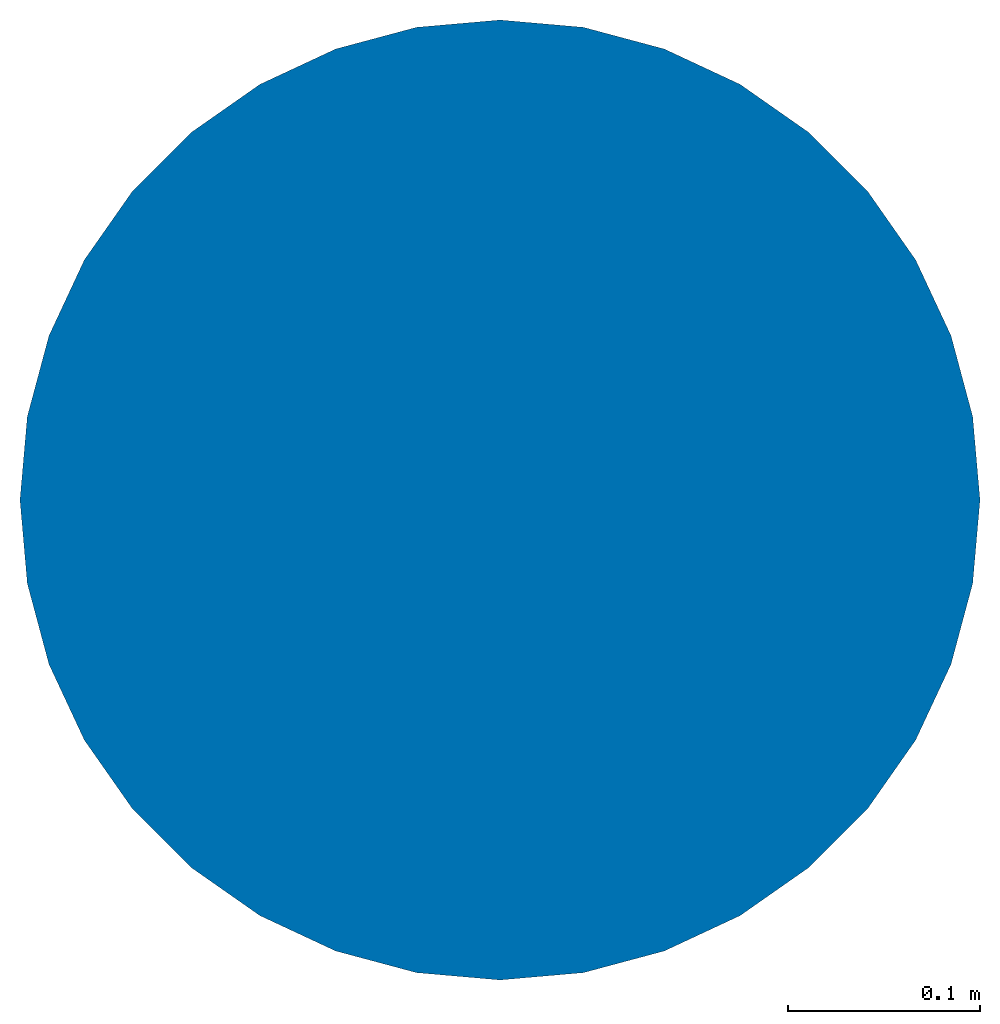
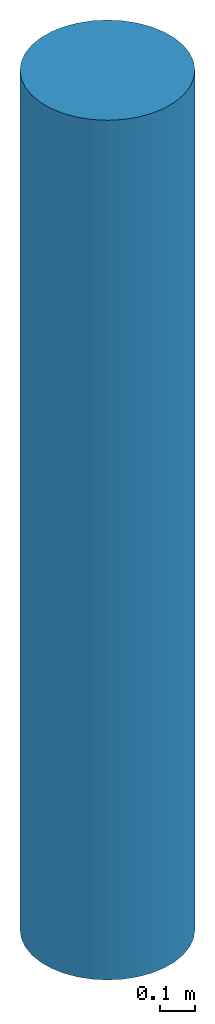
# One storey: 1 column.
"""IFC2X3 building model written with IfcOpenShell, lengths in millimetres."""

from ifc_helpers import new_model, entity, si_unit, converted_unit, derived_unit, money_unit, direction, frame, origin_with_axes, place, context, subcontext, project, spatial, faceted_brep, material, type_object, element, save


model = new_model("IFC2X3")

# Units and contexts
model_context = context("Model", 3, precision=1e-05, world=origin_with_axes(), true_north=direction((0.0, 1.0)))
body_context = subcontext(model_context, "Body", "Model", "MODEL_VIEW")
ifc_project = project(units=[si_unit("LENGTHUNIT", "METRE", prefix="MILLI"), si_unit("AREAUNIT", "SQUARE_METRE"), si_unit("VOLUMEUNIT", "CUBIC_METRE"), converted_unit("PLANEANGLEUNIT", "DEGREE", entity("IfcPlaneAngleMeasure", 0.0174532925199), si_unit("PLANEANGLEUNIT", "RADIAN"), dimensions=[0, 0, 0, 0, 0, 0, 0]), si_unit("SOLIDANGLEUNIT", "STERADIAN"), money_unit("USD"), converted_unit("TIMEUNIT", "Year", entity("IfcTimeMeasure", 31556926.0), si_unit("TIMEUNIT", "SECOND"), dimensions=[0, 0, 1, 0, 0, 0, 0]), si_unit("MASSUNIT", "GRAM", prefix="KILO"), si_unit("THERMODYNAMICTEMPERATUREUNIT", "DEGREE_CELSIUS"), si_unit("LUMINOUSINTENSITYUNIT", "LUMEN"), si_unit("ENERGYUNIT", "JOULE", prefix="MEGA"), derived_unit("THERMALCONDUCTANCEUNIT", [(si_unit("POWERUNIT", "WATT"), 1), (si_unit("LENGTHUNIT", "METRE"), -1), (si_unit("THERMODYNAMICTEMPERATUREUNIT", "KELVIN"), -1)]), derived_unit("SPECIFICHEATCAPACITYUNIT", [(si_unit("ENERGYUNIT", "JOULE"), 1), (si_unit("MASSUNIT", "GRAM", prefix="KILO"), -1), (si_unit("THERMODYNAMICTEMPERATUREUNIT", "KELVIN"), -1)]), derived_unit("MASSDENSITYUNIT", [(si_unit("MASSUNIT", "GRAM", prefix="KILO"), 1), (si_unit("VOLUMEUNIT", "CUBIC_METRE"), -1)])], contexts=[model_context])

# Site, building, storey
site_placement = place(None, origin_with_axes())
site = spatial("IfcSite", under=ifc_project, at=site_placement, CompositionType="ELEMENT")
building_placement = place(site_placement, origin_with_axes())
building = spatial("IfcBuilding", under=site, at=building_placement, CompositionType="ELEMENT")
storey_placement = place(building_placement, frame((0.0, 0.0, 500.0), z_axis=(0.0, 0.0, 1.0), x_axis=(1.0, 0.0, 0.0)))
storey = spatial("IfcBuildingStorey", under=building, at=storey_placement, Name="1FL", CompositionType="ELEMENT", Elevation=500.0)

# Column
ifc_material = material()
column_type = type_object("IfcColumnType", PredefinedType="NOTDEFINED")
column_placement = place(storey_placement, frame((852.21991327, 1196.77702465, 0.0), z_axis=(0.0, 0.0, 1.0), x_axis=(1.0, 0.0, 0.0)))
element("IfcColumn", 1, at=column_placement, inside=storey, type_object=column_type, material=ifc_material, Name="C1", context=body_context, shape_type="Brep", body=[
    faceted_brep([(-250.0, 0.0, 3000.0), (-250.0, 0.0, 0.0), (-246.201938253, -43.4120444167, 0.0), (-246.201938253, -43.4120444167, 3000.0), (-246.201938253, 43.4120444167, 3000.0), (-246.201938253, 43.4120444167, 0.0), (-234.923155196, 85.5050358314, 0.0), (-216.506350946, 125.0, 0.0), (-191.51111078, 160.696902422, 0.0), (-160.696902422, 191.51111078, 0.0), (-125.0, 216.506350946, 0.0), (-85.5050358314, 234.923155196, 0.0), (-43.4120444167, 246.201938253, 0.0), (0.0, 250.0, 0.0), (43.4120444167, 246.201938253, 0.0), (85.5050358314, 234.923155196, 0.0), (125.0, 216.506350946, 0.0), (160.696902422, 191.51111078, 0.0), (191.51111078, 160.696902422, 0.0), (216.506350946, 125.0, 0.0), (234.923155196, 85.5050358314, 0.0), (246.201938253, 43.4120444167, 0.0), (250.0, 0.0, 0.0), (246.201938253, -43.4120444167, 0.0), (234.923155196, -85.5050358314, 0.0), (216.506350946, -125.0, 0.0), (191.51111078, -160.696902422, 0.0), (160.696902422, -191.51111078, 0.0), (125.0, -216.506350946, 0.0), (85.5050358314, -234.923155196, 0.0), (43.4120444167, -246.201938253, 0.0), (0.0, -250.0, 0.0), (-43.4120444167, -246.201938253, 0.0), (-85.5050358314, -234.923155196, 0.0), (-125.0, -216.506350946, 0.0), (-160.696902422, -191.51111078, 0.0), (-191.51111078, -160.696902422, 0.0), (-216.506350946, -125.0, 0.0), (-234.923155196, -85.5050358314, 0.0), (-234.923155196, -85.5050358314, 3000.0), (-216.506350946, -125.0, 3000.0), (-191.51111078, -160.696902422, 3000.0), (-160.696902422, -191.51111078, 3000.0), (-125.0, -216.506350946, 3000.0), (-85.5050358314, -234.923155196, 3000.0), (-43.4120444167, -246.201938253, 3000.0), (0.0, -250.0, 3000.0), (43.4120444167, -246.201938253, 3000.0), (85.5050358314, -234.923155196, 3000.0), (125.0, -216.506350946, 3000.0), (160.696902422, -191.51111078, 3000.0), (191.51111078, -160.696902422, 3000.0), (216.506350946, -125.0, 3000.0), (234.923155196, -85.5050358314, 3000.0), (246.201938253, -43.4120444167, 3000.0), (250.0, 0.0, 3000.0), (246.201938253, 43.4120444167, 3000.0), (234.923155196, 85.5050358314, 3000.0), (216.506350946, 125.0, 3000.0), (191.51111078, 160.696902422, 3000.0), (160.696902422, 191.51111078, 3000.0), (125.0, 216.506350946, 3000.0), (85.5050358314, 234.923155196, 3000.0), (43.4120444167, 246.201938253, 3000.0), (0.0, 250.0, 3000.0), (-43.4120444167, 246.201938253, 3000.0), (-85.5050358314, 234.923155196, 3000.0), (-125.0, 216.506350946, 3000.0), (-160.696902422, 191.51111078, 3000.0), (-191.51111078, 160.696902422, 3000.0), (-216.506350946, 125.0, 3000.0), (-234.923155196, 85.5050358314, 3000.0)], [[[0, 1, 2, 3]], [[4, 5, 1, 0]], [[2, 1, 5, 6, 7, 8, 9, 10, 11, 12, 13, 14, 15, 16, 17, 18, 19, 20, 21, 22, 23, 24, 25, 26, 27, 28, 29, 30, 31, 32, 33, 34, 35, 36, 37, 38]], [[3, 2, 38, 39]], [[4, 0, 3, 39, 40, 41, 42, 43, 44, 45, 46, 47, 48, 49, 50, 51, 52, 53, 54, 55, 56, 57, 58, 59, 60, 61, 62, 63, 64, 65, 66, 67, 68, 69, 70, 71]], [[71, 6, 5, 4]], [[70, 7, 6, 71]], [[69, 8, 7, 70]], [[68, 9, 8, 69]], [[67, 10, 9, 68]], [[66, 11, 10, 67]], [[65, 12, 11, 66]], [[64, 13, 12, 65]], [[63, 14, 13, 64]], [[62, 15, 14, 63]], [[61, 16, 15, 62]], [[60, 17, 16, 61]], [[59, 18, 17, 60]], [[58, 19, 18, 59]], [[57, 20, 19, 58]], [[56, 21, 20, 57]], [[55, 22, 21, 56]], [[54, 23, 22, 55]], [[53, 24, 23, 54]], [[52, 25, 24, 53]], [[51, 26, 25, 52]], [[50, 27, 26, 51]], [[49, 28, 27, 50]], [[48, 29, 28, 49]], [[47, 30, 29, 48]], [[46, 31, 30, 47]], [[45, 32, 31, 46]], [[44, 33, 32, 45]], [[43, 34, 33, 44]], [[42, 35, 34, 43]], [[41, 36, 35, 42]], [[40, 37, 36, 41]], [[39, 38, 37, 40]]]),
])

save(model, "model.ifc")
